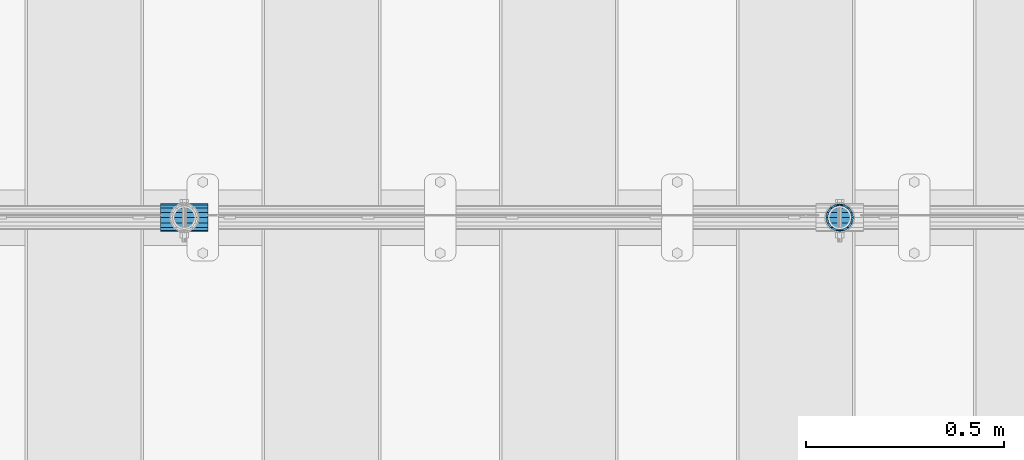
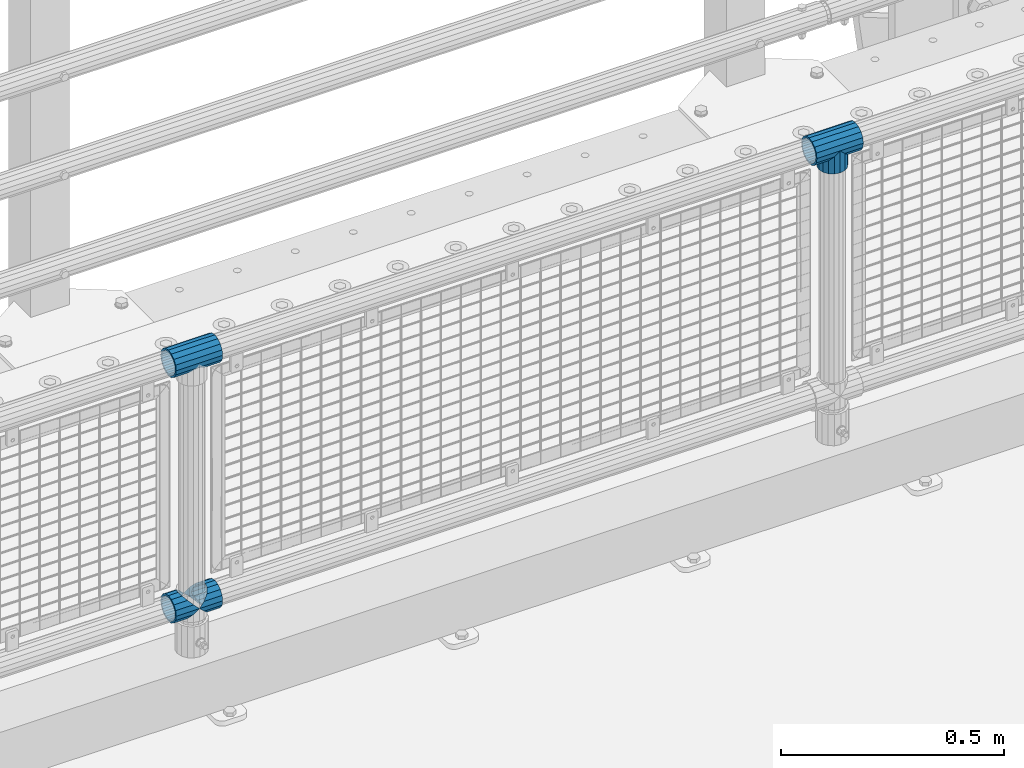
# One storey, part 141 of 219: 5 beams.
"""IFC2X3 building model written with IfcOpenShell, lengths in millimetres."""

from ifc_helpers import new_model, si_unit, frame, origin_with_axes, place, context, subcontext, project, spatial, faceted_brep, material, type_object, element, save


model = new_model("IFC2X3")

# Units and contexts
model_context = context("Model", 3, precision=1e-05, world=origin_with_axes())
body_context = subcontext(model_context, "Body", "Model", "MODEL_VIEW")
ifc_project = project(units=[si_unit("LENGTHUNIT", "METRE", prefix="MILLI"), si_unit("AREAUNIT", "SQUARE_METRE"), si_unit("VOLUMEUNIT", "CUBIC_METRE"), si_unit("MASSUNIT", "GRAM", prefix="KILO"), si_unit("TIMEUNIT", "SECOND"), si_unit("PLANEANGLEUNIT", "RADIAN"), si_unit("SOLIDANGLEUNIT", "STERADIAN"), si_unit("THERMODYNAMICTEMPERATUREUNIT", "DEGREE_CELSIUS"), si_unit("LUMINOUSINTENSITYUNIT", "LUMEN")], contexts=[model_context])

# Site, building, storey
site_placement = place(None, origin_with_axes())
site = spatial("IfcSite", under=ifc_project, at=site_placement, CompositionType="ELEMENT")
building_placement = place(site_placement, origin_with_axes())
building = spatial("IfcBuilding", under=site, at=building_placement, Name="Standard", CompositionType="ELEMENT")
storey_placement = place(building_placement, origin_with_axes())
storey = spatial("IfcBuildingStorey", under=building, at=storey_placement, Name="Undefined", CompositionType="ELEMENT", Elevation=0.0)

# Beams
ifc_material = material(Name="Misc_Undefined")
beam_type = type_object("IfcBeamType", PredefinedType="NOTDEFINED")
beam_1_placement = place(storey_placement, frame((8911.0, 31664.5, 969.849999999999), z_axis=(0.0, 1.0, 0.0), x_axis=(0.0, 0.0, -1.0)))
element("IfcBeam", 1, at=beam_1_placement, inside=storey, type_object=beam_type, material=ifc_material, context=body_context, shape_type="Brep", body=[
    faceted_brep([(0.0, 0.0, 35.1500000000015), (13.4513226476338, 13.4513226476329, 32.4743655677703), (13.4513226476338, -13.4513226476329, 32.4743655677703), (24.8548033587067, -16.3810424080013, -24.8548033587067), (24.8548033587067, -24.8548033587072, -24.8548033587067), (32.4743655677721, -32.4743655677717, -13.4513226476338), (32.4743655677721, -26.8123795176712, -13.4513226476338), (27.1226768591077, -21.4606908090117, -21.46069080901), (0.0, 0.0, -35.1500000000015), (13.4513226476338, -13.4513226476329, -32.4743655677703), (13.4513226476338, 13.4513226476329, -32.4743655677703), (20.0882031229739, -11.6144421722805, -28.0397438117179), (16.6306603983649, 0.0, -30.3499999999985), (20.0882031229739, 11.6144421722805, -28.0397438117179), (24.8548033587067, 16.3810424080013, -24.8548033587067), (24.8548033587067, 24.8548033587072, -24.8548033587067), (27.1226768591077, 21.4606908090117, -21.46069080901), (32.4743655677721, 26.8123795176755, -13.4513226476338), (32.4743655677721, 32.4743655677717, -13.4513226476338), (32.8397438117172, 28.0397438117175, -11.614442172282), (35.1499999999996, 30.35, 0.0), (35.1499999999996, 35.15, 0.0), (32.8397438117172, 28.0397438117175, 11.614442172282), (32.4743655677721, 26.8123795176755, 13.4513226476338), (32.4743655677721, 32.4743655677717, 13.4513226476338), (27.1226768591096, 21.4606908090117, 21.46069080901), (24.8548033587067, 16.3810424080078, 24.8548033587067), (24.8548033587067, 24.8548033587072, 24.8548033587067), (20.0882031229849, 11.6144421722805, 28.0397438117179), (16.6306603983739, 0.0, 30.3499999999985), (20.0882031229849, -11.6144421722805, 28.0397438117179), (24.8548033587067, -16.3810424080013, 24.8548033587067), (24.8548033587067, -24.8548033587072, 24.8548033587067), (27.1226768591096, -21.4606908090117, 21.46069080901), (32.4743655677721, -26.8123795176755, 13.4513226476338), (32.4743655677721, -32.4743655677717, 13.4513226476338), (32.8397438117172, -28.0397438117175, 11.614442172282), (35.1499999999996, -30.35, 0.0), (35.1499999999996, -35.15, 0.0), (32.8397438117172, -28.0397438117175, -11.614442172282), (60.1499999999996, -24.8548033587072, -24.8548033587067), (60.1499999999996, -32.4743655677717, -13.4513226476338), (60.1499999999996, -13.4513226476329, -32.4743655677703), (60.1499999999996, 0.0, -35.1500000000015), (60.1499999999996, 13.4513226476329, -32.4743655677703), (60.1499999999996, 24.8548033587072, -24.8548033587067), (60.1499999999996, 32.4743655677717, -13.4513226476338), (60.1499999999996, 35.15, 0.0), (60.1499999999996, 32.4743655677717, 13.4513226476338), (60.1499999999996, 24.8548033587072, 24.8548033587067), (60.1499999999996, 13.4513226476329, 32.4743655677703), (60.1499999999996, 0.0, 35.1500000000015), (60.1499999999996, -13.4513226476329, 32.4743655677703), (60.1499999999996, -24.8548033587072, 24.8548033587067), (60.1499999999996, -32.4743655677717, 13.4513226476338), (60.1499999999996, -35.15, 0.0), (60.1499999999996, -21.4606908090117, 21.46069080901), (60.1499999999996, -11.6144421722805, 28.0397438117179), (60.1499999999996, 0.0, 30.3499999999985), (60.1499999999996, 11.6144421722805, 28.0397438117179), (60.1499999999996, 21.4606908090117, 21.46069080901), (60.1499999999996, 28.0397438117175, 11.614442172282), (60.1499999999996, 30.35, 0.0), (60.1499999999996, 28.0397438117175, -11.614442172282), (60.1499999999996, 21.4606908090117, -21.46069080901), (60.1499999999996, 11.6144421722805, -28.0397438117179), (60.1499999999996, 0.0, -30.3499999999985), (60.1499999999996, -11.6144421722805, -28.0397438117179), (60.1499999999996, -21.4606908090117, -21.46069080901), (60.1499999999996, -28.0397438117175, -11.614442172282), (60.1499999999996, -30.35, 0.0), (60.1499999999996, -28.0397438117175, 11.614442172282)], [[[0, 1, 2]], [[3, 4, 5, 6, 7]], [[8, 9, 10]], [[10, 9, 4, 3, 11, 12, 13, 14, 15]], [[15, 14, 16, 17, 18]], [[18, 17, 19, 20, 21]], [[21, 20, 22, 23, 24]], [[24, 23, 25, 26, 27]], [[27, 26, 28, 29, 30, 31, 32, 2, 1]], [[33, 34, 35, 32, 31]], [[36, 37, 38, 35, 34]], [[6, 5, 38, 37, 39]], [[40, 41, 5, 4]], [[42, 40, 4, 9]], [[43, 42, 9, 8]], [[44, 43, 8, 10]], [[45, 44, 10, 15]], [[46, 45, 15, 18]], [[47, 46, 18, 21]], [[48, 47, 21, 24]], [[49, 48, 24, 27]], [[50, 49, 27, 1]], [[51, 50, 1, 0]], [[52, 51, 0, 2]], [[53, 52, 2, 32]], [[54, 53, 32, 35]], [[55, 54, 35, 38]], [[41, 55, 38, 5]], [[40, 42, 43, 44, 45, 46, 47, 48, 49, 50, 51, 52, 53, 54, 55, 41], [56, 57, 58, 59, 60, 61, 62, 63, 64, 65, 66, 67, 68, 69, 70, 71]], [[71, 70, 37, 36]], [[56, 71, 36, 34, 33]], [[57, 56, 33, 31, 30]], [[58, 57, 30, 29]], [[59, 58, 29, 28]], [[25, 60, 59, 28, 26]], [[22, 61, 60, 25, 23]], [[62, 61, 22, 20]], [[63, 62, 20, 19]], [[64, 63, 19, 17, 16]], [[65, 64, 16, 14, 13]], [[66, 65, 13, 12]], [[67, 66, 12, 11]], [[7, 68, 67, 11, 3]], [[39, 69, 68, 7, 6]], [[70, 69, 39, 37]]]),
])
beam_2_placement = place(storey_placement, frame((8850.85, 31664.5, 969.849999999999), z_axis=(0.0, 0.0, 1.0), x_axis=(1.0, 0.0, 0.0)))
element("IfcBeam", 2, at=beam_2_placement, inside=storey, type_object=beam_type, material=ifc_material, context=body_context, shape_type="Brep", body=[
    faceted_brep([(88.1897438117176, -11.614442172282, -28.0397438117176), (88.1897438117176, -11.614442172282, -32.8397438117162), (86.9623795176776, -13.4513226476338, -32.4743655677718), (81.6106908090114, -21.46069080901, -27.1226768591079), (81.6106908090114, -21.46069080901, -21.4606908090117), (76.5310424080035, -24.8548033587067, -24.8548033587072), (71.7644421722798, -28.0397438117179, -20.0882031229796), (71.7644421722798, -28.0397438117179, -11.6144421722805), (60.1499999999996, -30.3499999999985, -16.6306603983671), (60.1499999999996, -30.35, 0.0), (48.5355578277195, -28.0397438117179, -20.0882031229796), (48.5355578277195, -28.0397438117179, -11.6144421722805), (43.7689575919958, -24.8548033587067, -24.8548033587072), (38.6893091909878, -21.46069080901, -27.1226768591079), (38.6893091909878, -21.46069080901, -21.4606908090117), (33.3376204823271, -13.4513226476338, -32.4743655677718), (32.1102561882817, -11.614442172282, -32.8397438117162), (32.1102561882817, -11.614442172282, -28.0397438117176), (29.7999999999993, 0.0, -35.15), (29.7999999999993, 0.0, -30.35), (32.1102561882817, 11.614442172282, -32.8397438117171), (32.1102561882817, 11.614442172282, -28.0397438117176), (33.3376204823217, 13.4513226476338, -32.4743655677718), (38.6893091909878, 21.46069080901, -27.1226768591122), (38.6893091909878, 21.46069080901, -21.4606908090117), (43.7689575919958, 24.8548033587067, -24.8548033587072), (48.5355578277195, 28.0397438117179, -20.0882031229861), (48.5355578277195, 28.0397438117179, -11.6144421722805), (60.1499999999996, 30.3499999999985, -16.6306603983737), (60.1499999999996, 30.35, 0.0), (71.7644421722798, 28.0397438117179, -20.0882031229861), (71.7644421722798, 28.0397438117179, -11.6144421722805), (76.5310424080035, 24.8548033587067, -24.8548033587072), (81.6106908090114, 21.46069080901, -27.1226768591122), (81.6106908090114, 21.46069080901, -21.4606908090117), (86.9623795176722, 13.4513226476338, -32.4743655677718), (88.1897438117176, 11.614442172282, -32.8397438117171), (88.1897438117176, 11.614442172282, -28.0397438117176), (90.5, 0.0, -35.15), (90.5, 0.0, -30.35), (0.0, -21.46069080901, -21.4606908090118), (0.0, -28.0397438117179, -11.6144421722802), (0.0, -11.614442172282, -28.0397438117179), (0.0, 0.0, -30.3500000000004), (0.0, 11.614442172282, -28.0397438117179), (0.0, 21.46069080901, -21.4606908090118), (0.0, 28.0397438117179, -11.6144421722802), (0.0, 30.3499999999985, 0.0), (0.0, 32.4743655677703, -13.4513226476338), (0.0, 35.1500000000015, 0.0), (120.299999999999, 35.1500000000015, 0.0), (120.299999999999, 32.4743655677703, -13.4513226476329), (0.0, 32.4743655677703, 13.4513226476338), (120.299999999999, 32.4743655677703, 13.4513226476329), (0.0, 24.8548033587067, 24.8548033587067), (120.299999999999, 24.8548033587067, 24.8548033587072), (0.0, 13.4513226476338, 32.4743655677721), (120.299999999999, 13.4513226476338, 32.4743655677718), (0.0, 0.0, 35.1500000000015), (120.299999999999, 0.0, 35.15), (0.0, -13.4513226476338, 32.4743655677721), (120.299999999999, -13.4513226476338, 32.4743655677718), (0.0, -24.8548033587067, 24.8548033587067), (120.299999999999, -24.8548033587067, 24.8548033587072), (0.0, -32.4743655677703, 13.4513226476338), (120.299999999999, -32.4743655677703, 13.4513226476329), (0.0, -35.1500000000015, 0.0), (120.299999999999, -35.1500000000015, 0.0), (0.0, -32.4743655677703, -13.4513226476338), (120.299999999999, -32.4743655677703, -13.4513226476329), (0.0, 24.8548033587067, -24.8548033587067), (0.0, 13.4513226476338, -32.4743655677721), (0.0, 0.0, -35.1500000000015), (0.0, -13.4513226476338, -32.4743655677721), (0.0, -24.8548033587067, -24.8548033587067), (0.0, 28.0397438117179, 11.6144421722802), (0.0, 21.46069080901, 21.4606908090118), (0.0, 11.614442172282, 28.0397438117179), (0.0, 0.0, 30.3500000000004), (0.0, -11.614442172282, 28.0397438117179), (0.0, -21.46069080901, 21.4606908090118), (0.0, -28.0397438117179, 11.6144421722802), (0.0, -30.3499999999985, 0.0), (120.299999999999, -30.3499999999985, 0.0), (120.299999999999, -28.0397438117179, -11.6144421722805), (120.299999999999, -21.46069080901, -21.4606908090117), (120.299999999999, -11.614442172282, -28.0397438117176), (120.299999999999, 0.0, -30.35), (120.299999999999, 21.46069080901, -21.4606908090117), (120.299999999999, 28.0397438117179, -11.6144421722805), (120.299999999999, 11.614442172282, -28.0397438117176), (120.299999999999, 30.3499999999985, 0.0), (120.299999999999, 28.0397438117179, 11.6144421722805), (120.299999999999, 21.46069080901, 21.4606908090117), (120.299999999999, 11.614442172282, 28.0397438117176), (120.299999999999, 0.0, 30.35), (120.299999999999, -11.614442172282, 28.0397438117176), (120.299999999999, -21.46069080901, 21.4606908090117), (120.299999999999, -28.0397438117179, 11.6144421722805), (120.299999999999, -24.8548033587067, -24.8548033587072), (120.299999999999, -13.4513226476338, -32.4743655677718), (120.299999999999, 0.0, -35.15), (120.299999999999, 13.4513226476338, -32.4743655677718), (120.299999999999, 24.8548033587067, -24.8548033587072)], [[[0, 1, 2, 3, 4]], [[4, 3, 5, 6, 7]], [[7, 6, 8, 9]], [[9, 8, 10, 11]], [[11, 10, 12, 13, 14]], [[14, 13, 15, 16, 17]], [[17, 16, 18, 19]], [[19, 18, 20, 21]], [[21, 20, 22, 23, 24]], [[24, 23, 25, 26, 27]], [[27, 26, 28, 29]], [[29, 28, 30, 31]], [[31, 30, 32, 33, 34]], [[34, 33, 35, 36, 37]], [[37, 36, 38, 39]], [[39, 38, 1, 0]], [[40, 41, 11, 14]], [[42, 40, 14, 17]], [[43, 42, 17, 19]], [[44, 43, 19, 21]], [[45, 44, 21, 24]], [[46, 45, 24, 27]], [[47, 46, 27, 29]], [[48, 49, 50, 51]], [[49, 52, 53, 50]], [[52, 54, 55, 53]], [[54, 56, 57, 55]], [[56, 58, 59, 57]], [[58, 60, 61, 59]], [[60, 62, 63, 61]], [[62, 64, 65, 63]], [[64, 66, 67, 65]], [[66, 68, 69, 67]], [[64, 62, 60, 58, 56, 54, 52, 49, 48, 70, 71, 72, 73, 74, 68, 66], [41, 40, 42, 43, 44, 45, 46, 47, 75, 76, 77, 78, 79, 80, 81, 82]], [[41, 82, 9, 11]], [[83, 84, 7, 9]], [[84, 85, 4, 7]], [[85, 86, 0, 4]], [[86, 87, 39, 0]], [[88, 89, 31, 34]], [[90, 88, 34, 37]], [[87, 90, 37, 39]], [[89, 91, 29, 31]], [[75, 47, 29, 91, 92]], [[76, 75, 92, 93]], [[77, 76, 93, 94]], [[78, 77, 94, 95]], [[79, 78, 95, 96]], [[80, 79, 96, 97]], [[81, 80, 97, 98]], [[9, 82, 81, 98, 83]], [[99, 100, 101, 102, 103, 51, 50, 53, 55, 57, 59, 61, 63, 65, 67, 69], [97, 96, 95, 94, 93, 92, 91, 89, 88, 90, 87, 86, 85, 84, 83, 98]], [[35, 102, 101, 38, 36]], [[32, 103, 102, 35, 33]], [[28, 26, 25, 70, 48, 51, 103, 32, 30]], [[22, 71, 70, 25, 23]], [[18, 72, 71, 22, 20]], [[73, 72, 18, 16, 15]], [[74, 73, 15, 13, 12]], [[99, 69, 68, 74, 12, 10, 8, 6, 5]], [[100, 99, 5, 3, 2]], [[101, 100, 2, 1, 38]]]),
])
beam_3_placement = place(storey_placement, frame((7192.85, 31664.5, 969.849999999999), z_axis=(0.0, 0.0, 1.0), x_axis=(1.0, 0.0, 0.0)))
element("IfcBeam", 3, at=beam_3_placement, inside=storey, type_object=beam_type, material=ifc_material, context=body_context, shape_type="Brep", body=[
    faceted_brep([(88.1897438117176, -11.614442172282, -28.0397438117176), (88.1897438117176, -11.614442172282, -32.8397438117162), (86.9623795176776, -13.4513226476338, -32.4743655677718), (81.6106908090114, -21.46069080901, -27.1226768591079), (81.6106908090114, -21.46069080901, -21.4606908090117), (76.5310424080035, -24.8548033587067, -24.8548033587072), (71.7644421722798, -28.0397438117179, -20.0882031229796), (71.7644421722798, -28.0397438117179, -11.6144421722805), (60.1499999999996, -30.3499999999985, -16.6306603983671), (60.1499999999996, -30.35, 0.0), (48.5355578277195, -28.0397438117179, -20.0882031229796), (48.5355578277195, -28.0397438117179, -11.6144421722805), (43.7689575919958, -24.8548033587067, -24.8548033587072), (38.6893091909878, -21.46069080901, -27.1226768591079), (38.6893091909878, -21.46069080901, -21.4606908090117), (33.3376204823271, -13.4513226476338, -32.4743655677718), (32.1102561882817, -11.614442172282, -32.8397438117162), (32.1102561882817, -11.614442172282, -28.0397438117176), (29.7999999999993, 0.0, -35.15), (29.7999999999993, 0.0, -30.35), (32.1102561882817, 11.614442172282, -32.8397438117171), (32.1102561882817, 11.614442172282, -28.0397438117176), (33.3376204823217, 13.4513226476338, -32.4743655677718), (38.6893091909878, 21.46069080901, -27.1226768591122), (38.6893091909878, 21.46069080901, -21.4606908090117), (43.7689575919958, 24.8548033587067, -24.8548033587072), (48.5355578277195, 28.0397438117179, -20.0882031229861), (48.5355578277195, 28.0397438117179, -11.6144421722805), (60.1499999999996, 30.3499999999985, -16.6306603983737), (60.1499999999996, 30.35, 0.0), (71.7644421722798, 28.0397438117179, -20.0882031229861), (71.7644421722798, 28.0397438117179, -11.6144421722805), (76.5310424080035, 24.8548033587067, -24.8548033587072), (81.6106908090114, 21.46069080901, -27.1226768591122), (81.6106908090114, 21.46069080901, -21.4606908090117), (86.9623795176722, 13.4513226476338, -32.4743655677718), (88.1897438117176, 11.614442172282, -32.8397438117171), (88.1897438117176, 11.614442172282, -28.0397438117176), (90.5, 0.0, -35.15), (90.5, 0.0, -30.35), (0.0, -21.46069080901, -21.4606908090118), (0.0, -28.0397438117179, -11.6144421722802), (0.0, -11.614442172282, -28.0397438117179), (0.0, 0.0, -30.3500000000004), (0.0, 11.614442172282, -28.0397438117179), (0.0, 21.46069080901, -21.4606908090118), (0.0, 28.0397438117179, -11.6144421722802), (0.0, 30.3499999999985, 0.0), (0.0, 32.4743655677703, -13.4513226476338), (0.0, 35.1500000000015, 0.0), (120.299999999999, 35.1500000000015, 0.0), (120.299999999999, 32.4743655677703, -13.4513226476329), (0.0, 32.4743655677703, 13.4513226476338), (120.299999999999, 32.4743655677703, 13.4513226476329), (0.0, 24.8548033587067, 24.8548033587067), (120.299999999999, 24.8548033587067, 24.8548033587072), (0.0, 13.4513226476338, 32.4743655677721), (120.299999999999, 13.4513226476338, 32.4743655677718), (0.0, 0.0, 35.1500000000015), (120.299999999999, 0.0, 35.15), (0.0, -13.4513226476338, 32.4743655677721), (120.299999999999, -13.4513226476338, 32.4743655677718), (0.0, -24.8548033587067, 24.8548033587067), (120.299999999999, -24.8548033587067, 24.8548033587072), (0.0, -32.4743655677703, 13.4513226476338), (120.299999999999, -32.4743655677703, 13.4513226476329), (0.0, -35.1500000000015, 0.0), (120.299999999999, -35.1500000000015, 0.0), (0.0, -32.4743655677703, -13.4513226476338), (120.299999999999, -32.4743655677703, -13.4513226476329), (0.0, 24.8548033587067, -24.8548033587067), (0.0, 13.4513226476338, -32.4743655677721), (0.0, 0.0, -35.1500000000015), (0.0, -13.4513226476338, -32.4743655677721), (0.0, -24.8548033587067, -24.8548033587067), (0.0, 28.0397438117179, 11.6144421722802), (0.0, 21.46069080901, 21.4606908090118), (0.0, 11.614442172282, 28.0397438117179), (0.0, 0.0, 30.3500000000004), (0.0, -11.614442172282, 28.0397438117179), (0.0, -21.46069080901, 21.4606908090118), (0.0, -28.0397438117179, 11.6144421722802), (0.0, -30.3499999999985, 0.0), (120.299999999999, -30.3499999999985, 0.0), (120.299999999999, -28.0397438117179, -11.6144421722805), (120.299999999999, -21.46069080901, -21.4606908090117), (120.299999999999, -11.614442172282, -28.0397438117176), (120.299999999999, 0.0, -30.35), (120.299999999999, 21.46069080901, -21.4606908090117), (120.299999999999, 28.0397438117179, -11.6144421722805), (120.299999999999, 11.614442172282, -28.0397438117176), (120.299999999999, 30.3499999999985, 0.0), (120.299999999999, 28.0397438117179, 11.6144421722805), (120.299999999999, 21.46069080901, 21.4606908090117), (120.299999999999, 11.614442172282, 28.0397438117176), (120.299999999999, 0.0, 30.35), (120.299999999999, -11.614442172282, 28.0397438117176), (120.299999999999, -21.46069080901, 21.4606908090117), (120.299999999999, -28.0397438117179, 11.6144421722805), (120.299999999999, -24.8548033587067, -24.8548033587072), (120.299999999999, -13.4513226476338, -32.4743655677718), (120.299999999999, 0.0, -35.15), (120.299999999999, 13.4513226476338, -32.4743655677718), (120.299999999999, 24.8548033587067, -24.8548033587072)], [[[0, 1, 2, 3, 4]], [[4, 3, 5, 6, 7]], [[7, 6, 8, 9]], [[9, 8, 10, 11]], [[11, 10, 12, 13, 14]], [[14, 13, 15, 16, 17]], [[17, 16, 18, 19]], [[19, 18, 20, 21]], [[21, 20, 22, 23, 24]], [[24, 23, 25, 26, 27]], [[27, 26, 28, 29]], [[29, 28, 30, 31]], [[31, 30, 32, 33, 34]], [[34, 33, 35, 36, 37]], [[37, 36, 38, 39]], [[39, 38, 1, 0]], [[40, 41, 11, 14]], [[42, 40, 14, 17]], [[43, 42, 17, 19]], [[44, 43, 19, 21]], [[45, 44, 21, 24]], [[46, 45, 24, 27]], [[47, 46, 27, 29]], [[48, 49, 50, 51]], [[49, 52, 53, 50]], [[52, 54, 55, 53]], [[54, 56, 57, 55]], [[56, 58, 59, 57]], [[58, 60, 61, 59]], [[60, 62, 63, 61]], [[62, 64, 65, 63]], [[64, 66, 67, 65]], [[66, 68, 69, 67]], [[64, 62, 60, 58, 56, 54, 52, 49, 48, 70, 71, 72, 73, 74, 68, 66], [41, 40, 42, 43, 44, 45, 46, 47, 75, 76, 77, 78, 79, 80, 81, 82]], [[41, 82, 9, 11]], [[83, 84, 7, 9]], [[84, 85, 4, 7]], [[85, 86, 0, 4]], [[86, 87, 39, 0]], [[88, 89, 31, 34]], [[90, 88, 34, 37]], [[87, 90, 37, 39]], [[89, 91, 29, 31]], [[75, 47, 29, 91, 92]], [[76, 75, 92, 93]], [[77, 76, 93, 94]], [[78, 77, 94, 95]], [[79, 78, 95, 96]], [[80, 79, 96, 97]], [[81, 80, 97, 98]], [[9, 82, 81, 98, 83]], [[99, 100, 101, 102, 103, 51, 50, 53, 55, 57, 59, 61, 63, 65, 67, 69], [97, 96, 95, 94, 93, 92, 91, 89, 88, 90, 87, 86, 85, 84, 83, 98]], [[35, 102, 101, 38, 36]], [[32, 103, 102, 35, 33]], [[28, 26, 25, 70, 48, 51, 103, 32, 30]], [[22, 71, 70, 25, 23]], [[18, 72, 71, 22, 20]], [[73, 72, 18, 16, 15]], [[74, 73, 15, 13, 12]], [[99, 69, 68, 74, 12, 10, 8, 6, 5]], [[100, 99, 5, 3, 2]], [[101, 100, 2, 1, 38]]]),
])
beam_4_placement = place(storey_placement, frame((7192.85, 31664.5, 298.17), z_axis=(0.0, 1.0, 0.0), x_axis=(1.0, 0.0, 0.0)))
element("IfcBeam", 4, at=beam_4_placement, inside=storey, type_object=beam_type, material=ifc_material, context=body_context, shape_type="Brep", body=[
    faceted_brep([(60.1499999999996, 0.0, -35.1500000000015), (46.6986773523668, 13.4513226476329, -32.4743655677703), (46.6986773523668, -13.4513226476329, -32.4743655677703), (33.0273231408928, 21.4606908090117, 21.46069080901), (27.675634432228, 26.8123795176712, 13.4513226476338), (27.675634432228, 32.4743655677717, 13.4513226476338), (35.2951966412925, 24.8548033587072, 24.8548033587067), (35.2951966412925, 16.3810424080078, 24.8548033587067), (27.3102561882824, 28.0397438117175, 11.614442172282), (24.9999999999995, 30.35, 0.0), (24.9999999999995, 35.15, 0.0), (27.675634432228, 26.8123795176755, -13.4513226476338), (27.675634432228, 32.4743655677717, -13.4513226476338), (27.3102561882829, 28.0397438117175, -11.614442172282), (35.2951966412925, 16.3810424080013, -24.8548033587067), (35.2951966412925, 24.8548033587072, -24.8548033587067), (33.0273231408896, 21.4606908090117, -21.46069080901), (40.0617968770143, 11.6144421722805, -28.0397438117179), (43.5193396016266, 0.0, -30.3499999999985), (40.0617968770143, -11.6144421722805, -28.0397438117179), (35.2951966412925, -16.3810424080013, -24.8548033587067), (35.2951966412925, -24.8548033587072, -24.8548033587067), (33.0273231408896, -21.4606908090117, -21.46069080901), (27.675634432228, -26.8123795176755, -13.4513226476338), (27.675634432228, -32.4743655677717, -13.4513226476338), (27.3102561882829, -28.0397438117175, -11.614442172282), (24.9999999999995, -30.35, 0.0), (24.9999999999995, -35.15, 0.0), (27.3102561882824, -28.0397438117175, 11.614442172282), (27.675634432228, -26.8123795176755, 13.4513226476338), (27.675634432228, -32.4743655677717, 13.4513226476338), (33.0273231408928, -21.4606908090117, 21.46069080901), (35.2951966412925, -16.3810424080013, 24.8548033587067), (35.2951966412925, -24.8548033587072, 24.8548033587067), (60.1499999999996, 0.0, 35.1500000000015), (46.6986773523668, -13.4513226476329, 32.4743655677703), (46.6986773523668, 13.4513226476329, 32.4743655677703), (40.0617968770207, -11.6144421722805, 28.0397438117179), (43.519339601633, 0.0, 30.3499999999985), (40.0617968770207, 11.6144421722805, 28.0397438117179), (0.0, -32.4743655677703, -13.4513226476338), (0.0, -24.8548033587067, -24.8548033587067), (0.0, -13.4513226476338, -32.4743655677721), (0.0, 0.0, -35.1500000000015), (0.0, 13.4513226476338, -32.4743655677721), (0.0, 24.8548033587067, -24.8548033587067), (0.0, 32.4743655677703, -13.4513226476338), (0.0, 35.1500000000015, 0.0), (0.0, 32.4743655677703, 13.4513226476338), (0.0, 24.8548033587067, 24.8548033587067), (0.0, 13.4513226476338, 32.4743655677721), (0.0, 0.0, 35.1500000000015), (0.0, -32.4743655677703, 13.4513226476338), (0.0, -35.1500000000015, 0.0), (0.0, -24.8548033587067, 24.8548033587067), (0.0, -13.4513226476338, 32.4743655677721), (0.0, -28.0397438117179, -11.6144421722802), (0.0, -21.46069080901, -21.4606908090118), (0.0, -11.614442172282, -28.0397438117179), (0.0, 0.0, -30.3500000000004), (0.0, 11.614442172282, -28.0397438117179), (0.0, 21.46069080901, -21.4606908090118), (0.0, 28.0397438117179, -11.6144421722802), (0.0, 30.3499999999985, 0.0), (0.0, 28.0397438117179, 11.6144421722802), (0.0, 21.46069080901, 21.4606908090118), (0.0, 11.614442172282, 28.0397438117179), (0.0, 0.0, 30.3500000000004), (0.0, -11.614442172282, 28.0397438117179), (0.0, -21.46069080901, 21.4606908090118), (0.0, -28.0397438117179, 11.6144421722802), (0.0, -30.3499999999985, 0.0)], [[[0, 1, 2]], [[3, 4, 5, 6, 7]], [[8, 9, 10, 5, 4]], [[11, 12, 10, 9, 13]], [[14, 15, 12, 11, 16]], [[2, 1, 15, 14, 17, 18, 19, 20, 21]], [[21, 20, 22, 23, 24]], [[24, 23, 25, 26, 27]], [[27, 26, 28, 29, 30]], [[30, 29, 31, 32, 33]], [[34, 35, 36]], [[33, 32, 37, 38, 39, 7, 6, 36, 35]], [[40, 41, 21, 24]], [[41, 42, 2, 21]], [[42, 43, 0, 2]], [[43, 44, 1, 0]], [[44, 45, 15, 1]], [[45, 46, 12, 15]], [[46, 47, 10, 12]], [[47, 48, 5, 10]], [[48, 49, 6, 5]], [[49, 50, 36, 6]], [[50, 51, 34, 36]], [[52, 53, 27, 30]], [[54, 52, 30, 33]], [[55, 54, 33, 35]], [[51, 55, 35, 34]], [[53, 40, 24, 27]], [[52, 54, 55, 51, 50, 49, 48, 47, 46, 45, 44, 43, 42, 41, 40, 53], [56, 57, 58, 59, 60, 61, 62, 63, 64, 65, 66, 67, 68, 69, 70, 71]], [[68, 67, 38, 37]], [[31, 69, 68, 37, 32]], [[28, 70, 69, 31, 29]], [[71, 70, 28, 26]], [[56, 71, 26, 25]], [[57, 56, 25, 23, 22]], [[58, 57, 22, 20, 19]], [[59, 58, 19, 18]], [[60, 59, 18, 17]], [[16, 61, 60, 17, 14]], [[13, 62, 61, 16, 11]], [[63, 62, 13, 9]], [[64, 63, 9, 8]], [[65, 64, 8, 4, 3]], [[66, 65, 3, 7, 39]], [[67, 66, 39, 38]]]),
])
beam_5_placement = place(storey_placement, frame((7253.0, 31664.5, 298.17), z_axis=(0.0, 1.0, 0.0), x_axis=(1.0, 0.0, 0.0)))
element("IfcBeam", 5, at=beam_5_placement, inside=storey, type_object=beam_type, material=ifc_material, context=body_context, shape_type="Brep", body=[
    faceted_brep([(0.0, 0.0, 35.1500000000015), (13.4513226476338, 13.4513226476329, 32.4743655677703), (13.4513226476338, -13.4513226476329, 32.4743655677703), (24.8548033587067, -16.3810424080013, -24.8548033587067), (24.8548033587067, -24.8548033587072, -24.8548033587067), (32.4743655677721, -32.4743655677717, -13.4513226476338), (32.4743655677721, -26.8123795176712, -13.4513226476338), (27.1226768591077, -21.4606908090117, -21.46069080901), (0.0, 0.0, -35.1500000000015), (13.4513226476338, -13.4513226476329, -32.4743655677703), (13.4513226476338, 13.4513226476329, -32.4743655677703), (20.0882031229739, -11.6144421722805, -28.0397438117179), (16.6306603983649, 0.0, -30.3499999999985), (20.0882031229739, 11.6144421722805, -28.0397438117179), (24.8548033587067, 16.3810424080013, -24.8548033587067), (24.8548033587067, 24.8548033587072, -24.8548033587067), (27.1226768591077, 21.4606908090117, -21.46069080901), (32.4743655677721, 26.8123795176755, -13.4513226476338), (32.4743655677721, 32.4743655677717, -13.4513226476338), (32.8397438117172, 28.0397438117175, -11.614442172282), (35.1499999999996, 30.35, 0.0), (35.1499999999996, 35.15, 0.0), (32.8397438117172, 28.0397438117175, 11.614442172282), (32.4743655677721, 26.8123795176755, 13.4513226476338), (32.4743655677721, 32.4743655677717, 13.4513226476338), (27.1226768591096, 21.4606908090117, 21.46069080901), (24.8548033587067, 16.3810424080078, 24.8548033587067), (24.8548033587067, 24.8548033587072, 24.8548033587067), (20.0882031229849, 11.6144421722805, 28.0397438117179), (16.6306603983739, 0.0, 30.3499999999985), (20.0882031229849, -11.6144421722805, 28.0397438117179), (24.8548033587067, -16.3810424080013, 24.8548033587067), (24.8548033587067, -24.8548033587072, 24.8548033587067), (27.1226768591096, -21.4606908090117, 21.46069080901), (32.4743655677721, -26.8123795176755, 13.4513226476338), (32.4743655677721, -32.4743655677717, 13.4513226476338), (32.8397438117172, -28.0397438117175, 11.614442172282), (35.1499999999996, -30.35, 0.0), (35.1499999999996, -35.15, 0.0), (32.8397438117172, -28.0397438117175, -11.614442172282), (60.1499999999996, -24.8548033587072, -24.8548033587067), (60.1499999999996, -32.4743655677717, -13.4513226476338), (60.1499999999996, -13.4513226476329, -32.4743655677703), (60.1499999999996, 0.0, -35.1500000000015), (60.1499999999996, 13.4513226476329, -32.4743655677703), (60.1499999999996, 24.8548033587072, -24.8548033587067), (60.1499999999996, 32.4743655677717, -13.4513226476338), (60.1499999999996, 35.15, 0.0), (60.1499999999996, 32.4743655677717, 13.4513226476338), (60.1499999999996, 24.8548033587072, 24.8548033587067), (60.1499999999996, 13.4513226476329, 32.4743655677703), (60.1499999999996, 0.0, 35.1500000000015), (60.1499999999996, -13.4513226476329, 32.4743655677703), (60.1499999999996, -24.8548033587072, 24.8548033587067), (60.1499999999996, -32.4743655677717, 13.4513226476338), (60.1499999999996, -35.15, 0.0), (60.1499999999996, -21.4606908090117, 21.46069080901), (60.1499999999996, -11.6144421722805, 28.0397438117179), (60.1499999999996, 0.0, 30.3499999999985), (60.1499999999996, 11.6144421722805, 28.0397438117179), (60.1499999999996, 21.4606908090117, 21.46069080901), (60.1499999999996, 28.0397438117175, 11.614442172282), (60.1499999999996, 30.35, 0.0), (60.1499999999996, 28.0397438117175, -11.614442172282), (60.1499999999996, 21.4606908090117, -21.46069080901), (60.1499999999996, 11.6144421722805, -28.0397438117179), (60.1499999999996, 0.0, -30.3499999999985), (60.1499999999996, -11.6144421722805, -28.0397438117179), (60.1499999999996, -21.4606908090117, -21.46069080901), (60.1499999999996, -28.0397438117175, -11.614442172282), (60.1499999999996, -30.35, 0.0), (60.1499999999996, -28.0397438117175, 11.614442172282)], [[[0, 1, 2]], [[3, 4, 5, 6, 7]], [[8, 9, 10]], [[10, 9, 4, 3, 11, 12, 13, 14, 15]], [[15, 14, 16, 17, 18]], [[18, 17, 19, 20, 21]], [[21, 20, 22, 23, 24]], [[24, 23, 25, 26, 27]], [[27, 26, 28, 29, 30, 31, 32, 2, 1]], [[33, 34, 35, 32, 31]], [[36, 37, 38, 35, 34]], [[6, 5, 38, 37, 39]], [[40, 41, 5, 4]], [[42, 40, 4, 9]], [[43, 42, 9, 8]], [[44, 43, 8, 10]], [[45, 44, 10, 15]], [[46, 45, 15, 18]], [[47, 46, 18, 21]], [[48, 47, 21, 24]], [[49, 48, 24, 27]], [[50, 49, 27, 1]], [[51, 50, 1, 0]], [[52, 51, 0, 2]], [[53, 52, 2, 32]], [[54, 53, 32, 35]], [[55, 54, 35, 38]], [[41, 55, 38, 5]], [[40, 42, 43, 44, 45, 46, 47, 48, 49, 50, 51, 52, 53, 54, 55, 41], [56, 57, 58, 59, 60, 61, 62, 63, 64, 65, 66, 67, 68, 69, 70, 71]], [[71, 70, 37, 36]], [[56, 71, 36, 34, 33]], [[57, 56, 33, 31, 30]], [[58, 57, 30, 29]], [[59, 58, 29, 28]], [[25, 60, 59, 28, 26]], [[22, 61, 60, 25, 23]], [[62, 61, 22, 20]], [[63, 62, 20, 19]], [[64, 63, 19, 17, 16]], [[65, 64, 16, 14, 13]], [[66, 65, 13, 12]], [[67, 66, 12, 11]], [[7, 68, 67, 11, 3]], [[39, 69, 68, 7, 6]], [[70, 69, 39, 37]]]),
])

save(model, "model.ifc")
